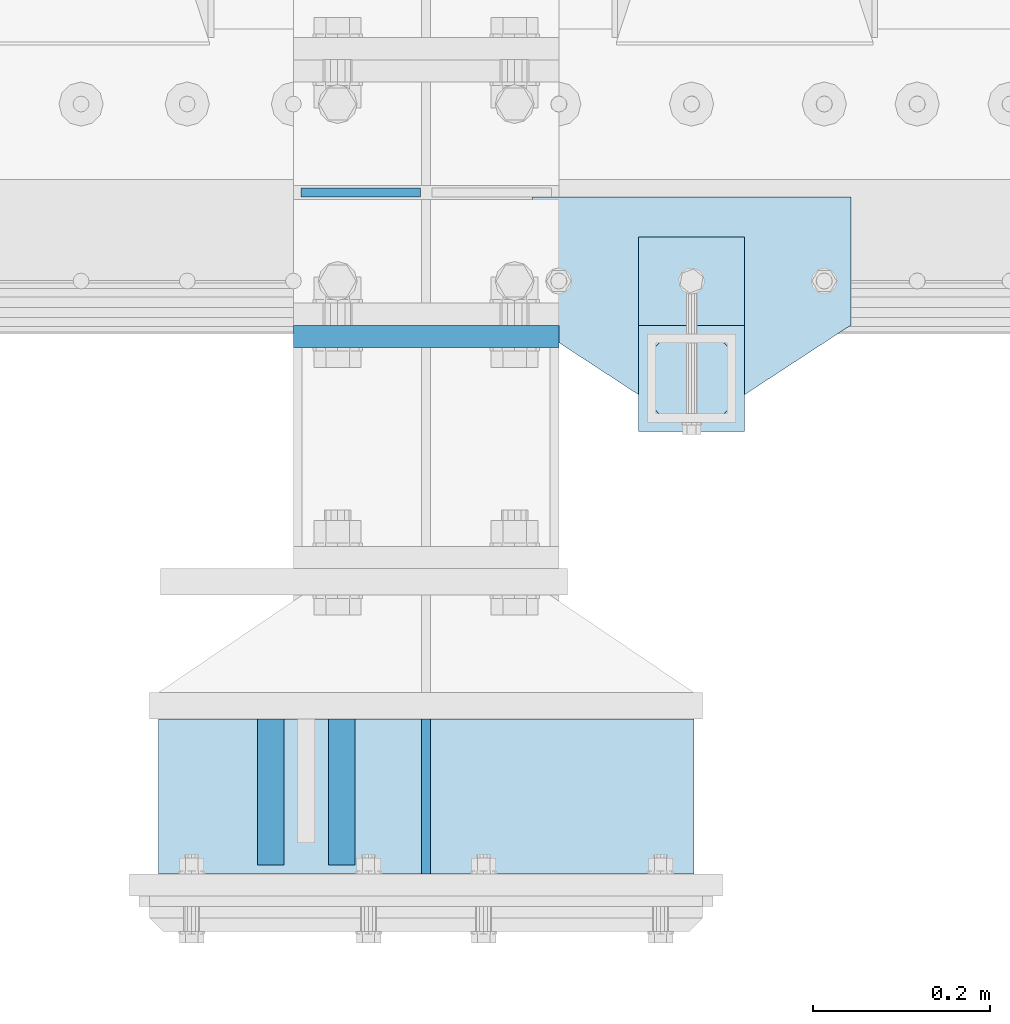
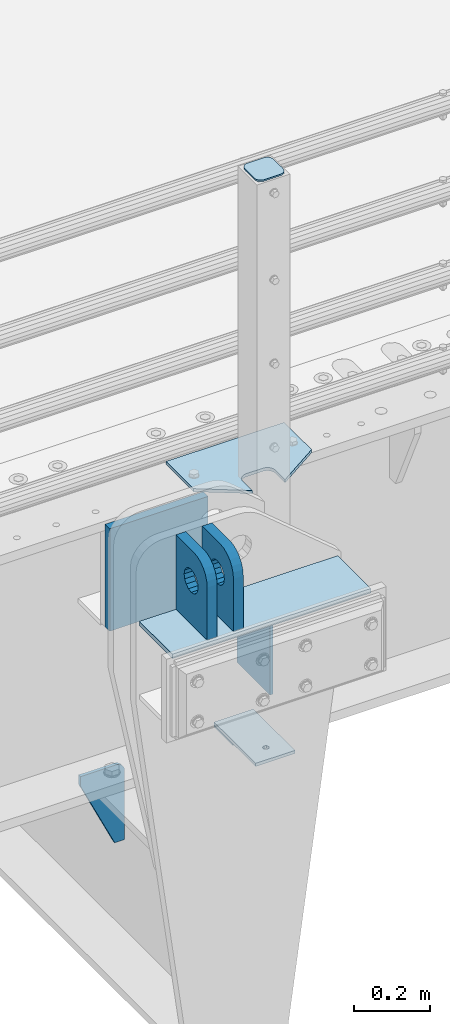
# One storey, part 165 of 193: 10 plates.
"""IFC2X3 building model written with IfcOpenShell, lengths in millimetres."""

from ifc_helpers import new_model, si_unit, frame, origin_with_axes, place, context, subcontext, project, spatial, faceted_brep, material, type_object, element, save


model = new_model("IFC2X3")

# Units and contexts
model_context = context("Model", 3, precision=1e-05, world=origin_with_axes())
body_context = subcontext(model_context, "Body", "Model", "MODEL_VIEW")
ifc_project = project(units=[si_unit("LENGTHUNIT", "METRE", prefix="MILLI"), si_unit("AREAUNIT", "SQUARE_METRE"), si_unit("VOLUMEUNIT", "CUBIC_METRE"), si_unit("MASSUNIT", "GRAM", prefix="KILO"), si_unit("TIMEUNIT", "SECOND"), si_unit("PLANEANGLEUNIT", "RADIAN"), si_unit("SOLIDANGLEUNIT", "STERADIAN"), si_unit("THERMODYNAMICTEMPERATUREUNIT", "DEGREE_CELSIUS"), si_unit("LUMINOUSINTENSITYUNIT", "LUMEN")], contexts=[model_context])

# Site, building, storey
site_placement = place(None, origin_with_axes())
site = spatial("IfcSite", under=ifc_project, at=site_placement, CompositionType="ELEMENT")
building_placement = place(site_placement, origin_with_axes())
building = spatial("IfcBuilding", under=site, at=building_placement, Name="Standard", CompositionType="ELEMENT")
storey_placement = place(building_placement, origin_with_axes())
storey = spatial("IfcBuildingStorey", under=building, at=storey_placement, Name="Undefined", CompositionType="ELEMENT", Elevation=0.0)

# Plates
ifc_material_1 = material(Name="STEEL/S355N")
plate_type_1 = type_object("IfcPlateType", PredefinedType="NOTDEFINED")
plate_1_placement = place(storey_placement, frame((-32059.9999999331, 23229.9999999953, -14.000018206186), z_axis=(0.0, 0.0, -1.0), x_axis=(0.0, 1.0, 0.0)))
element("IfcPlate", 1, at=plate_1_placement, inside=storey, type_object=plate_type_1, material=ifc_material_1, context=body_context, shape_type="Brep", body=[
    faceted_brep([(0.0, -5.0, 0.0), (0.0, -5.0, 222.0), (0.0, 5.0, 222.0), (0.0, 5.0, 0.0), (175.0, -5.0, 222.0), (175.0, 5.0, 222.0), (175.0, -5.0, 0.0), (175.0, 5.0, 0.0)], [[[0, 1, 2, 3]], [[1, 4, 5, 2]], [[4, 6, 7, 5]], [[6, 0, 3, 7]], [[5, 7, 3, 2]], [[6, 4, 1, 0]]]),
])
plate_type_2 = type_object("IfcPlateType", PredefinedType="NOTDEFINED")
plate_2_placement = place(storey_placement, frame((-32155.5000001316, 23405.0000000058, -1.8238333723275e-05), z_axis=(0.0, -1.0, 0.0), x_axis=(0.0, 0.0, 1.0)))
element("IfcPlate", 2, at=plate_2_placement, inside=storey, type_object=plate_type_2, material=ifc_material_1, context=body_context, shape_type="Brep", body=[
    faceted_brep([(125.840713002497, -14.9999995435392, 45.8164574470793), (125.840713002497, 15.0000004564608, 45.816457147077), (113.837049096103, 15.0000005366674, 53.837048946094), (113.837049096103, -14.9999994633326, 53.8370492460963), (105.816457297088, 15.0000006567025, 65.8407128524887), (105.816457297088, -14.9999993432975, 65.8407131524909), (103.000000000005, 15.0000007982962, 79.9999998499952), (103.000000000005, -14.9999992017038, 80.0000001499975), (105.816457297088, 15.00000093989, 94.1592868475018), (105.816457297088, -14.99999906011, 94.1592871475041), (113.837049096103, 15.0000010599251, 106.162950753896), (113.837049096103, -14.9999989400749, 106.162951053899), (125.840713002497, 15.0000011401316, 114.183542552913), (125.840713002497, -14.9999988598684, 114.183542852916), (140.000000000005, 15.0000011682969, 116.999999849995), (140.000000000005, -14.9999988317031, 117.000000149998), (154.159286997514, 15.0000011401316, 114.183542552913), (154.159286997514, -14.9999988598684, 114.183542852916), (166.162950903908, 15.0000010599251, 106.162950753896), (166.162950903908, -14.9999989400749, 106.162951053899), (174.183542702923, 15.00000093989, 94.1592868475018), (174.183542702923, -14.99999906011, 94.1592871475041), (177.000000000005, 15.0000007982962, 79.9999998499952), (177.000000000005, -14.9999992017038, 80.0000001499975), (174.183542702923, 15.0000006567025, 65.8407128524887), (174.183542702923, -14.9999993432975, 65.8407131524909), (166.162950903908, 15.0000005366674, 53.837048946094), (166.162950903908, -14.9999994633326, 53.8370492460963), (154.159286997514, 15.0000004564608, 45.816457147077), (154.159286997514, -14.9999995435392, 45.8164574470793), (140.000000000005, 15.0000004282956, 42.9999998499952), (140.000000000005, -14.9999995717044, 43.0000001499975), (240.000015258789, -14.9999999999964, -2.07364792004228e-10), (240.001666876698, -15.0, 94.9959403776193), (237.616787699976, -15.0, 113.113322498932), (230.624045898169, -15.0, 129.996116868064), (219.499985670386, -14.9999999999964, 144.49378797986), (205.002693976271, -14.9999999999964, 155.61834267445), (188.120138118986, -15.0, 162.611660295064), (170.002837349484, -15.0, 164.99715740146), (-1.40620068123098e-06, -15.0, 164.999999999996), (0.0, -15.0, 0.0), (0.0, 15.0, 0.0), (240.000015258789, 15.0000000000036, -2.11002770811319e-10), (240.001666876698, 15.0, 94.9959403776193), (237.616787699976, 15.0, 113.113322498928), (230.624045898169, 15.0, 129.99611686806), (219.499985670386, 15.0000000000036, 144.493787979856), (205.002693976271, 15.0000000000036, 155.618342674446), (188.120138118986, 15.0, 162.611660295061), (170.002837349484, 15.0, 164.997157401456), (-1.40620068123098e-06, 15.0, 164.999999999996)], [[[0, 1, 2, 3]], [[3, 2, 4, 5]], [[5, 4, 6, 7]], [[7, 6, 8, 9]], [[9, 8, 10, 11]], [[11, 10, 12, 13]], [[13, 12, 14, 15]], [[15, 14, 16, 17]], [[17, 16, 18, 19]], [[19, 18, 20, 21]], [[21, 20, 22, 23]], [[23, 22, 24, 25]], [[25, 24, 26, 27]], [[27, 26, 28, 29]], [[29, 28, 30, 31]], [[31, 30, 1, 0]], [[32, 33, 34, 35, 36, 37, 38, 39, 40, 41], [3, 5, 7, 9, 11, 13, 15, 17, 19, 21, 23, 25, 27, 29, 31, 0]], [[32, 41, 42, 43]], [[33, 32, 43, 44]], [[34, 33, 44, 45]], [[35, 34, 45, 46]], [[36, 35, 46, 47]], [[37, 36, 47, 48]], [[38, 37, 48, 49]], [[39, 38, 49, 50]], [[40, 39, 50, 51]], [[41, 40, 51, 42]], [[50, 49, 48, 47, 46, 45, 44, 43, 42, 51], [26, 24, 22, 20, 18, 16, 14, 12, 10, 8, 6, 4, 2, 1, 30, 28]]]),
])
plate_3_placement = place(storey_placement, frame((-32235.5000001299, 23405.0000000058, -1.8238333723275e-05), z_axis=(0.0, -1.0, 0.0), x_axis=(0.0, 0.0, 1.0)))
element("IfcPlate", 3, at=plate_3_placement, inside=storey, type_object=plate_type_2, material=ifc_material_1, context=body_context, shape_type="Brep", body=[
    faceted_brep([(125.840713002497, -14.9999995435392, 45.8164574470793), (125.840713002497, 15.0000004564608, 45.816457147077), (113.837049096103, 15.0000005366674, 53.837048946094), (113.837049096103, -14.9999994633326, 53.8370492460963), (105.816457297088, 15.0000006567025, 65.8407128524887), (105.816457297088, -14.9999993432975, 65.8407131524909), (103.000000000005, 15.0000007982962, 79.9999998499952), (103.000000000005, -14.9999992017038, 80.0000001499975), (105.816457297088, 15.00000093989, 94.1592868475018), (105.816457297088, -14.99999906011, 94.1592871475041), (113.837049096103, 15.0000010599251, 106.162950753896), (113.837049096103, -14.9999989400749, 106.162951053899), (125.840713002497, 15.0000011401316, 114.183542552913), (125.840713002497, -14.9999988598684, 114.183542852916), (140.000000000005, 15.0000011682969, 116.999999849995), (140.000000000005, -14.9999988317031, 117.000000149998), (154.159286997514, 15.0000011401316, 114.183542552913), (154.159286997514, -14.9999988598684, 114.183542852916), (166.162950903908, 15.0000010599251, 106.162950753896), (166.162950903908, -14.9999989400749, 106.162951053899), (174.183542702923, 15.00000093989, 94.1592868475018), (174.183542702923, -14.99999906011, 94.1592871475041), (177.000000000005, 15.0000007982962, 79.9999998499952), (177.000000000005, -14.9999992017038, 80.0000001499975), (174.183542702923, 15.0000006567025, 65.8407128524887), (174.183542702923, -14.9999993432975, 65.8407131524909), (166.162950903908, 15.0000005366674, 53.837048946094), (166.162950903908, -14.9999994633326, 53.8370492460963), (154.159286997514, 15.0000004564608, 45.816457147077), (154.159286997514, -14.9999995435392, 45.8164574470793), (140.000000000005, 15.0000004282956, 42.9999998499952), (140.000000000005, -14.9999995717044, 43.0000001499975), (240.000015258789, -14.9999999999964, -2.07364792004228e-10), (240.0, -15.0, 95.0), (237.614807840235, -15.0, 113.117333157177), (230.621778264911, -15.0, 130.0), (219.497474683058, -15.0, 144.497474683059), (205.0, -15.0, 155.621778264911), (188.117333157176, -15.0, 162.614807840237), (170.0, -15.0, 165.0), (-1.40620068123098e-06, -15.0, 164.999999999996), (0.0, -15.0, 0.0), (0.0, 15.0, 0.0), (240.000015258789, 15.0000000000036, -2.11002770811319e-10), (240.0, 15.0, 95.0), (237.614807840235, 15.0, 113.117333157177), (230.621778264911, 15.0, 130.0), (219.497474683058, 15.0, 144.497474683059), (205.0, 15.0, 155.621778264911), (188.117333157176, 15.0, 162.614807840237), (170.0, 15.0, 165.0), (-1.40620068123098e-06, 15.0, 164.999999999996)], [[[0, 1, 2, 3]], [[3, 2, 4, 5]], [[5, 4, 6, 7]], [[7, 6, 8, 9]], [[9, 8, 10, 11]], [[11, 10, 12, 13]], [[13, 12, 14, 15]], [[15, 14, 16, 17]], [[17, 16, 18, 19]], [[19, 18, 20, 21]], [[21, 20, 22, 23]], [[23, 22, 24, 25]], [[25, 24, 26, 27]], [[27, 26, 28, 29]], [[29, 28, 30, 31]], [[31, 30, 1, 0]], [[32, 33, 34, 35, 36, 37, 38, 39, 40, 41], [3, 5, 7, 9, 11, 13, 15, 17, 19, 21, 23, 25, 27, 29, 31, 0]], [[32, 41, 42, 43]], [[33, 32, 43, 44]], [[34, 33, 44, 45]], [[35, 34, 45, 46]], [[36, 35, 46, 47]], [[37, 36, 47, 48]], [[38, 37, 48, 49]], [[39, 38, 49, 50]], [[40, 39, 50, 51]], [[41, 40, 51, 42]], [[50, 49, 48, 47, 46, 45, 44, 43, 42, 51], [26, 24, 22, 20, 18, 16, 14, 12, 10, 8, 6, 4, 2, 1, 30, 28]]]),
])
plate_type_3 = type_object("IfcPlateType", PredefinedType="NOTDEFINED")
plate_4_placement = place(storey_placement, frame((-32209.9999999337, 23837.4999999954, -340.000018206186), z_axis=(0.0, 0.0, 1.0), x_axis=(1.0, 0.0, 0.0)))
element("IfcPlate", 4, at=plate_4_placement, inside=storey, type_object=plate_type_3, material=ifc_material_1, context=body_context, shape_type="Brep", body=[
    faceted_brep([(0.0, -12.5, 0.0), (0.0, -12.5, 330.0), (0.0, 12.5, 330.0), (0.0, 12.5, 0.0), (300.0, -12.5, 330.0), (300.0, 12.5, 330.0), (300.0, -12.5, 0.0), (300.0, 12.5, 0.0)], [[[0, 1, 2, 3]], [[1, 4, 5, 2]], [[4, 6, 7, 5]], [[6, 0, 3, 7]], [[5, 7, 3, 2]], [[6, 4, 1, 0]]]),
])
plate_type_4 = type_object("IfcPlateType", PredefinedType="NOTDEFINED")
plate_5_placement = place(storey_placement, frame((-32066.4999999334, 23999.9999999954, -915.000018206184), z_axis=(0.0, 0.0, -1.0), x_axis=(-1.0, 0.0, 0.0)))
element("IfcPlate", 5, at=plate_5_placement, inside=storey, type_object=plate_type_4, material=ifc_material_1, context=body_context, shape_type="Brep", body=[
    faceted_brep([(0.0, -5.0, 27.0), (0.0, -5.0, 250.0), (0.0, 5.0, 250.0), (0.0, 5.0, 27.0), (30.0, -5.0, 250.0), (30.0, 5.0, 250.0), (135.0, -5.0, 30.0), (135.0, 5.0, 30.0), (135.0, -5.0, 0.0), (135.0, 5.0, 0.0), (27.0, -5.0, 0.0), (27.0, 5.0, 0.0), (22.3114992029914, -5.0, 0.410190668670339), (22.3114992029914, 5.0, 0.410190668670339), (17.7654561302079, -5.0, 1.62829923878041), (17.7654561302079, 5.0, 1.62829923878041), (13.5, -5.0, 3.61731409782021), (13.5, 5.0, 3.61731409782021), (9.64473453846222, -5.0, 6.31680003578765), (9.64473453846222, 5.0, 6.31680003578765), (6.31680003578731, -5.0, 9.64473453846347), (6.31680003578731, 5.0, 9.64473453846347), (3.61731409782078, -5.0, 13.5), (3.61731409782078, 5.0, 13.5), (1.62829923877871, -5.0, 17.765456130207), (1.62829923877871, 5.0, 17.765456130207), (0.410190668670111, -5.0, 22.3114992029929), (0.410190668670111, 5.0, 22.3114992029929)], [[[0, 1, 2, 3]], [[1, 4, 5, 2]], [[4, 6, 7, 5]], [[6, 8, 9, 7]], [[8, 10, 11, 9]], [[10, 12, 13, 11]], [[12, 14, 15, 13]], [[14, 16, 17, 15]], [[16, 18, 19, 17]], [[18, 20, 21, 19]], [[20, 22, 23, 21]], [[22, 24, 25, 23]], [[24, 26, 27, 25]], [[26, 0, 3, 27]], [[5, 7, 9, 11, 13, 15, 17, 19, 21, 23, 25, 27, 3, 2]], [[26, 24, 22, 20, 18, 16, 14, 12, 10, 8, 6, 4, 1, 0]]]),
])
ifc_material_2 = material(Name="STEEL/S355J2")
plate_type_5 = type_object("IfcPlateType", PredefinedType="NOTDEFINED")
plate_6_placement = place(storey_placement, frame((-31580.0, 23995.0, 5.00000000004911), z_axis=(0.0, -1.0, 0.0), x_axis=(-1.0, 0.0, 0.0)))
element("IfcPlate", 6, at=plate_6_placement, inside=storey, type_object=plate_type_5, material=ifc_material_2, context=body_context, shape_type="Brep", body=[
    faceted_brep([(0.0, -5.0, 0.0), (2.31396552408114e-06, -5.0, 145.0), (2.31396552408114e-06, 5.0, 145.0), (0.0, 5.0, 0.0), (130.0, -5.0, 230.0), (130.0, 5.0, 230.0), (130.0, -5.0, 180.0), (130.0, 5.0, 180.0), (130.48036798992, -5.0, 175.122741949595), (130.48036798992, 5.0, 175.122741949595), (131.903011687216, -5.0, 170.432914190871), (131.903011687216, 5.0, 170.432914190871), (134.213259692435, -5.0, 166.110744174512), (134.213259692435, 5.0, 166.110744174512), (137.322330470335, -5.0, 162.322330470335), (137.322330470335, 5.0, 162.322330470335), (141.110744174512, -5.0, 159.213259692435), (141.110744174512, 5.0, 159.213259692435), (145.432914190871, -5.0, 156.903011687216), (145.432914190871, 5.0, 156.903011687216), (150.122741949595, -5.0, 155.48036798992), (150.122741949595, 5.0, 155.48036798992), (155.0, -5.0, 155.0), (155.0, 5.0, 155.0), (205.0, -5.0, 155.0), (205.0, 5.0, 155.0), (209.877258050405, -5.0, 155.48036798992), (209.877258050405, 5.0, 155.48036798992), (214.567085809129, -5.0, 156.903011687216), (214.567085809129, 5.0, 156.903011687216), (218.889255825488, -5.0, 159.213259692435), (218.889255825488, 5.0, 159.213259692435), (222.677669529665, -5.0, 162.322330470335), (222.677669529665, 5.0, 162.322330470335), (225.786740307565, -5.0, 166.110744174512), (225.786740307565, 5.0, 166.110744174512), (228.096988312784, -5.0, 170.432914190871), (228.096988312784, 5.0, 170.432914190871), (229.51963201008, -5.0, 175.122741949595), (229.51963201008, 5.0, 175.122741949595), (230.0, -5.0, 180.0), (230.0, 5.0, 180.0), (230.0, -5.0, 230.0), (230.0, 5.0, 230.0), (360.0, -5.0, 145.0), (360.0, 5.0, 145.0), (360.0, -5.0, -7.27595761418343e-12), (360.0, 5.0, -7.27595761418343e-12)], [[[0, 1, 2, 3]], [[1, 4, 5, 2]], [[4, 6, 7, 5]], [[6, 8, 9, 7]], [[8, 10, 11, 9]], [[10, 12, 13, 11]], [[12, 14, 15, 13]], [[14, 16, 17, 15]], [[16, 18, 19, 17]], [[18, 20, 21, 19]], [[20, 22, 23, 21]], [[22, 24, 25, 23]], [[24, 26, 27, 25]], [[26, 28, 29, 27]], [[28, 30, 31, 29]], [[30, 32, 33, 31]], [[32, 34, 35, 33]], [[34, 36, 37, 35]], [[36, 38, 39, 37]], [[38, 40, 41, 39]], [[40, 42, 43, 41]], [[42, 44, 45, 43]], [[44, 46, 47, 45]], [[46, 0, 3, 47]], [[5, 7, 9, 11, 13, 15, 17, 19, 21, 23, 25, 27, 29, 31, 33, 35, 37, 39, 41, 43, 45, 47, 3, 2]], [[46, 44, 42, 40, 38, 36, 34, 32, 30, 28, 26, 24, 22, 20, 18, 16, 14, 12, 10, 8, 6, 4, 1, 0]]]),
])
plate_type_6 = type_object("IfcPlateType", PredefinedType="NOTDEFINED")
plate_7_placement = place(storey_placement, frame((-31700.0000000001, 23949.9999999998, -850.000000000002), z_axis=(0.0, -1.0, 0.0), x_axis=(-1.0, 0.0, 0.0)))
element("IfcPlate", 7, at=plate_7_placement, inside=storey, type_object=plate_type_6, material=ifc_material_2, context=body_context, shape_type="Brep", body=[
    faceted_brep([(53.6360389691836, -5.0, 176.363961030467), (53.6360389691836, 5.0, 176.363961030467), (59.9999999998618, 5.0, 178.999999999789), (59.9999999998618, -5.0, 178.999999999789), (66.3639610305399, 5.0, 176.363961030467), (66.3639610305399, -5.0, 176.363961030467), (68.9999999998618, 5.0, 169.999999999789), (68.9999999998618, -5.0, 169.999999999789), (66.3639610305399, 5.0, 163.636038969111), (66.3639610305399, -5.0, 163.636038969111), (59.9999999998618, 5.0, 160.999999999789), (59.9999999998618, -5.0, 160.999999999789), (53.6360389691836, 5.0, 163.636038969111), (53.6360389691836, -5.0, 163.636038969111), (50.9999999998618, 5.0, 169.999999999789), (50.9999999998618, -5.0, 169.999999999789), (120.0, -5.0, 0.0), (120.0, -5.0, 220.0), (0.0, -5.0, 220.0), (0.0, -5.0, 0.0), (0.0, 5.0, 0.0), (120.0, 5.0, 0.0), (120.0, 5.0, 220.0), (0.0, 5.0, 220.0)], [[[0, 1, 2, 3]], [[3, 2, 4, 5]], [[5, 4, 6, 7]], [[7, 6, 8, 9]], [[9, 8, 10, 11]], [[11, 10, 12, 13]], [[13, 12, 14, 15]], [[15, 14, 1, 0]], [[16, 17, 18, 19], [11, 13, 15, 0, 3, 5, 7, 9]], [[16, 19, 20, 21]], [[17, 16, 21, 22]], [[18, 17, 22, 23]], [[19, 18, 23, 20]], [[22, 21, 20, 23], [2, 1, 14, 12, 10, 8, 6, 4]]]),
])
plate_type_7 = type_object("IfcPlateType", PredefinedType="NOTDEFINED")
plate_8_placement = place(storey_placement, frame((-31804.0000000001, 23833.9999999998, 1012.50000000001), z_axis=(0.0, -1.0, 0.0), x_axis=(1.0, 0.0, 0.0)))
element("IfcPlate", 8, at=plate_8_placement, inside=storey, type_object=plate_type_7, material=ifc_material_2, context=body_context, shape_type="Brep", body=[
    faceted_brep([(0.0, -2.5, 19.0), (0.0, -2.5, 69.0), (0.0, 2.5, 69.0), (0.0, 2.5, 19.0), (0.476369668544066, -2.5, 73.2278977451715), (0.476369668544066, 2.5, 73.2278977451715), (1.88159150985302, -2.5, 77.2437910432345), (1.88159150985302, 2.5, 77.2437910432345), (4.14520183310742, -2.5, 80.8463062353148), (4.14520183310742, 2.5, 80.8463062353148), (7.15369376468516, -2.5, 83.8547981668926), (7.15369376468516, 2.5, 83.8547981668926), (10.7562089567655, -2.5, 86.118408490147), (10.7562089567655, 2.5, 86.118408490147), (14.7721022548285, -2.5, 87.5236303314559), (14.7721022548285, 2.5, 87.5236303314559), (19.0, -2.5, 88.0), (19.0, 2.5, 88.0), (69.0, -2.5, 88.0), (69.0, 2.5, 88.0), (73.2278977451715, -2.5, 87.5236303314559), (73.2278977451715, 2.5, 87.5236303314559), (77.2437910432345, -2.5, 86.118408490147), (77.2437910432345, 2.5, 86.118408490147), (80.8463062353148, -2.5, 83.8547981668926), (80.8463062353148, 2.5, 83.8547981668926), (83.8547981668926, -2.5, 80.8463062353148), (83.8547981668926, 2.5, 80.8463062353148), (86.118408490147, -2.5, 77.2437910432345), (86.118408490147, 2.5, 77.2437910432345), (87.5236303314559, -2.5, 73.2278977451715), (87.5236303314559, 2.5, 73.2278977451715), (88.0, -2.5, 69.0), (88.0, 2.5, 69.0), (88.0, -2.5, 19.0), (88.0, 2.5, 19.0), (87.5236303314559, -2.5, 14.7721022548285), (87.5236303314559, 2.5, 14.7721022548285), (86.118408490147, -2.5, 10.7562089567655), (86.118408490147, 2.5, 10.7562089567655), (83.8547981668926, -2.5, 7.15369376468516), (83.8547981668926, 2.5, 7.15369376468516), (80.8463062353148, -2.5, 4.14520183310742), (80.8463062353148, 2.5, 4.14520183310742), (77.2437910432345, -2.5, 1.88159150985302), (77.2437910432345, 2.5, 1.88159150985302), (73.2278977451715, -2.5, 0.476369668544066), (73.2278977451715, 2.5, 0.476369668544066), (69.0, -2.5, 0.0), (69.0, 2.5, 0.0), (19.0, -2.5, 0.0), (19.0, 2.5, 0.0), (14.7721022548285, -2.5, 0.476369668544066), (14.7721022548285, 2.5, 0.476369668544066), (10.7562089567655, -2.5, 1.88159150985302), (10.7562089567655, 2.5, 1.88159150985302), (7.15369376468516, -2.5, 4.14520183310742), (7.15369376468516, 2.5, 4.14520183310742), (4.14520183310742, -2.5, 7.15369376468516), (4.14520183310742, 2.5, 7.15369376468516), (1.88159150985302, -2.5, 10.7562089567655), (1.88159150985302, 2.5, 10.7562089567655), (0.476369668544066, -2.5, 14.7721022548285), (0.476369668544066, 2.5, 14.7721022548285)], [[[0, 1, 2, 3]], [[1, 4, 5, 2]], [[4, 6, 7, 5]], [[6, 8, 9, 7]], [[8, 10, 11, 9]], [[10, 12, 13, 11]], [[12, 14, 15, 13]], [[14, 16, 17, 15]], [[16, 18, 19, 17]], [[18, 20, 21, 19]], [[20, 22, 23, 21]], [[22, 24, 25, 23]], [[24, 26, 27, 25]], [[26, 28, 29, 27]], [[28, 30, 31, 29]], [[30, 32, 33, 31]], [[32, 34, 35, 33]], [[34, 36, 37, 35]], [[36, 38, 39, 37]], [[38, 40, 41, 39]], [[40, 42, 43, 41]], [[42, 44, 45, 43]], [[44, 46, 47, 45]], [[46, 48, 49, 47]], [[48, 50, 51, 49]], [[50, 52, 53, 51]], [[52, 54, 55, 53]], [[54, 56, 57, 55]], [[56, 58, 59, 57]], [[58, 60, 61, 59]], [[60, 62, 63, 61]], [[62, 0, 3, 63]], [[5, 7, 9, 11, 13, 15, 17, 19, 21, 23, 25, 27, 29, 31, 33, 35, 37, 39, 41, 43, 45, 47, 49, 51, 53, 55, 57, 59, 61, 63, 3, 2]], [[62, 60, 58, 56, 54, 52, 50, 48, 46, 44, 42, 40, 38, 36, 34, 32, 30, 28, 26, 24, 22, 20, 18, 16, 14, 12, 10, 8, 6, 4, 1, 0]]]),
])
plate_type_8 = type_object("IfcPlateType", PredefinedType="NOTDEFINED")
plate_9_placement = place(storey_placement, frame((-31700.0000000001, 23949.9999999998, -857.500000000002), z_axis=(0.0, -1.0, 0.0), x_axis=(-1.0, 0.0, 0.0)))
element("IfcPlate", 9, at=plate_9_placement, inside=storey, type_object=plate_type_8, material=ifc_material_2, context=body_context, shape_type="Brep", body=[
    faceted_brep([(0.0, -2.5, 0.0), (0.0, -2.5, 100.0), (0.0, 2.5, 100.0), (0.0, 2.5, 0.0), (120.0, -2.5, 100.0), (120.0, 2.5, 100.0), (120.0, -2.5, 0.0), (120.0, 2.5, 0.0)], [[[0, 1, 2, 3]], [[1, 4, 5, 2]], [[4, 6, 7, 5]], [[6, 0, 3, 7]], [[5, 7, 3, 2]], [[6, 4, 1, 0]]]),
])
ifc_material_3 = material()
plate_type_9 = type_object("IfcPlateType", PredefinedType="NOTDEFINED")
plate_10_placement = place(storey_placement, frame((-31757.4999999323, 23404.9999999953, -7.00001820618604), z_axis=(0.0, -1.0, 0.0), x_axis=(-1.0, 0.0, 0.0)))
element("IfcPlate", 10, at=plate_10_placement, inside=storey, type_object=plate_type_9, material=ifc_material_3, context=body_context, shape_type="Brep", body=[
    faceted_brep([(0.0, -7.0, 0.0), (0.0, -7.0, 175.0), (0.0, 7.0, 175.0), (0.0, 7.0, 0.0), (605.0, -7.0, 175.0), (605.0, 7.0, 175.0), (605.0, -7.0, 0.0), (605.0, 7.0, 0.0)], [[[0, 1, 2, 3]], [[1, 4, 5, 2]], [[4, 6, 7, 5]], [[6, 0, 3, 7]], [[5, 7, 3, 2]], [[6, 4, 1, 0]]]),
])

save(model, "model.ifc")
